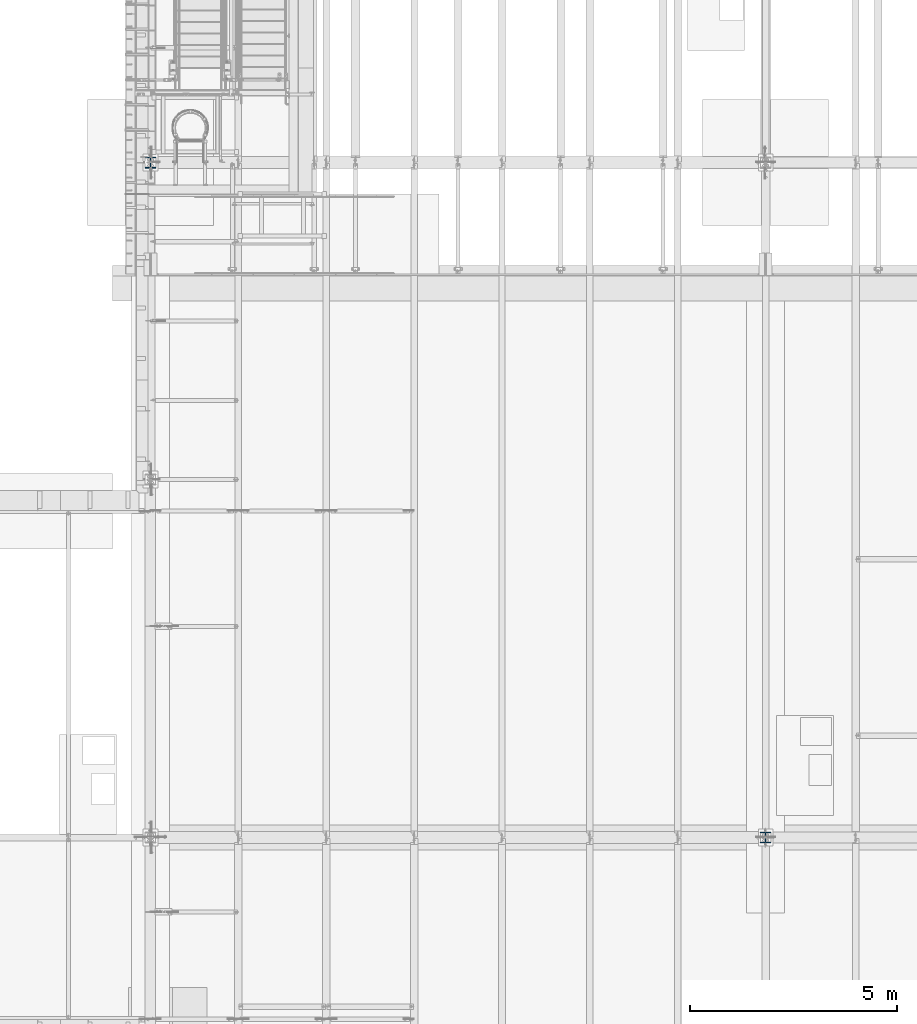
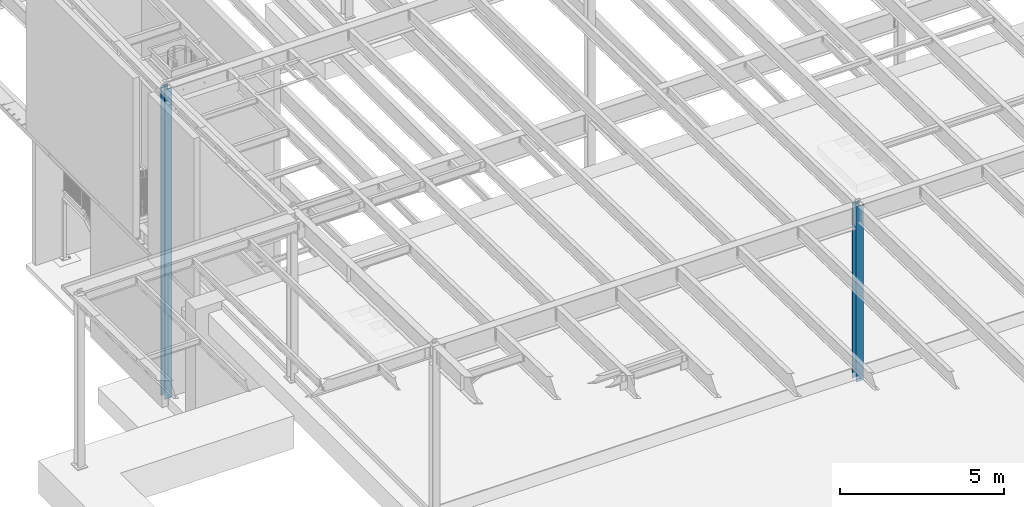
# One storey, part 900 of 1763: 2 columns, 2 elements without a shape of their own.
"""IFC2X3 building model written with IfcOpenShell, lengths in millimetres."""

from ifc_helpers import new_model, si_unit, frame, origin_with_axes, place, context, subcontext, project, spatial, faceted_brep, material, type_object, element, aggregate, save


model = new_model("IFC2X3")

# Units and contexts
model_context = context("Model", 3, precision=1e-05, world=origin_with_axes())
body_context = subcontext(model_context, "Body", "Model", "MODEL_VIEW")
ifc_project = project(units=[si_unit("LENGTHUNIT", "METRE", prefix="MILLI"), si_unit("AREAUNIT", "SQUARE_METRE"), si_unit("VOLUMEUNIT", "CUBIC_METRE"), si_unit("MASSUNIT", "GRAM", prefix="KILO"), si_unit("TIMEUNIT", "SECOND"), si_unit("PLANEANGLEUNIT", "RADIAN"), si_unit("SOLIDANGLEUNIT", "STERADIAN"), si_unit("THERMODYNAMICTEMPERATUREUNIT", "DEGREE_CELSIUS"), si_unit("LUMINOUSINTENSITYUNIT", "LUMEN")], contexts=[model_context])

# Site, building, storey
site_placement = place(None, origin_with_axes())
site = spatial("IfcSite", under=ifc_project, at=site_placement, CompositionType="ELEMENT")
building_placement = place(site_placement, origin_with_axes())
building = spatial("IfcBuilding", under=site, at=building_placement, Name="Undefined", CompositionType="ELEMENT")
storey_placement = place(building_placement, origin_with_axes())
storey = spatial("IfcBuildingStorey", under=building, at=storey_placement, Name="Undefined", CompositionType="ELEMENT", Elevation=0.0)

# Assembly, column
assembly_1_placement = place(storey_placement, origin_with_axes())
assembly_1 = element("IfcElementAssembly", 1, at=assembly_1_placement, inside=storey, Name="COLUMN", AssemblyPlace="NOTDEFINED", PredefinedType="RIGID_FRAME")
ifc_material = material(Name="STEEL/A992")
column_type_1 = type_object("IfcColumnType", Name="W10X49", PredefinedType="NOTDEFINED")
column_1_placement = place(assembly_1_placement, frame((-72491.0372736984, 13690.6, 5029.2), z_axis=(0.0, 1.0, 0.0), x_axis=(0.0, 0.0, 1.0)))
column_1 = element("IfcColumn", 2, at=column_1_placement, type_object=column_type_1, material=ifc_material, Name="COLUMN", ObjectType="W10X49", context=body_context, shape_type="Brep", body=[
    faceted_brep([(69.8500000000085, 127.0, -127.0), (69.8500000000085, 127.0, -112.712500000001), (6589.7125, 127.0, -112.7125), (6589.7125, 127.0, -127.0), (69.8500000000085, 3.96875, -112.712500000001), (6589.7125, 3.96875, -112.7125), (69.8500000000085, 3.96875, 112.712500000001), (6589.7125, 3.96875, 112.7125), (69.8500000000085, 127.0, 112.712500000001), (6589.7125, 127.0, 112.7125), (69.8500000000085, 127.0, 127.0), (6589.7125, 127.0, 127.0), (69.8500000000085, -127.0, 127.0), (6589.7125, -127.0, 127.0), (69.8500000000085, -127.0, 112.712500000001), (6589.7125, -127.0, 112.7125), (69.8500000000085, -3.96875, 112.712500000001), (6589.7125, -3.96875, 112.7125), (69.8500000000085, -3.96875, -112.712500000001), (6589.7125, -3.96875, -112.7125), (69.8500000000085, -127.0, -112.712500000001), (6589.7125, -127.0, -112.7125), (69.8500000000085, -127.0, -127.0), (6589.7125, -127.0, -127.0)], [[[0, 1, 2, 3]], [[1, 4, 5, 2]], [[4, 6, 7, 5]], [[6, 8, 9, 7]], [[8, 10, 11, 9]], [[10, 12, 13, 11]], [[12, 14, 15, 13]], [[14, 16, 17, 15]], [[16, 18, 19, 17]], [[18, 20, 21, 19]], [[20, 22, 23, 21]], [[22, 0, 3, 23]], [[5, 7, 9, 11, 13, 15, 17, 19, 21, 23, 3, 2]], [[22, 20, 18, 16, 14, 12, 10, 8, 6, 4, 1, 0]]]),
])
aggregate(assembly_1, [column_1])

assembly_2_placement = place(storey_placement, origin_with_axes())
assembly_2 = element("IfcElementAssembly", 3, at=assembly_2_placement, inside=storey, Name="COLUMN", AssemblyPlace="NOTDEFINED", PredefinedType="RIGID_FRAME")
column_type_2 = type_object("IfcColumnType", Name="W10X68", PredefinedType="NOTDEFINED")
column_2_placement = place(assembly_2_placement, frame((-87375.4372736983, 30022.8, -304.8), z_axis=(0.0, 1.0, 0.0), x_axis=(0.0, 0.0, 1.0)))
column_2 = element("IfcColumn", 4, at=column_2_placement, type_object=column_type_2, material=ifc_material, Name="COLUMN", ObjectType="W10X68", context=body_context, shape_type="Brep", body=[
    faceted_brep([(69.8499999999952, 128.587499999994, -131.762500000001), (69.8499999999952, 128.587499999994, -112.712500000001), (11582.3999999952, 128.587499999994, -112.712500000001), (11582.3999999952, 128.587499999994, -131.762500000001), (69.8499999999952, 6.35000000000582, -112.712500000001), (11582.3999999952, 6.35000000000582, -112.712500000001), (69.8499999999952, 6.35000000000582, 112.712500000001), (11582.3999999952, 6.35000000000582, 112.712500000001), (69.8499999999952, 128.587499999994, 112.712500000001), (11582.3999999952, 128.587499999994, 112.712500000001), (69.8499999999952, 128.587499999994, 131.762500000001), (11582.3999999952, 128.587499999994, 131.762500000001), (69.8499999999952, -128.587499999994, 131.762500000001), (11582.3999999952, -128.587499999994, 131.762500000001), (69.8499999999952, -128.587499999994, 112.712500000001), (11582.3999999952, -128.587499999994, 112.712500000001), (69.8499999999952, -6.35000000000582, 112.712500000001), (11582.3999999952, -6.35000000000582, 112.712500000001), (69.8499999999952, -6.35000000000582, -112.712500000001), (11582.3999999952, -6.35000000000582, -112.712500000001), (69.8499999999952, -128.587499999994, -112.712500000001), (11582.3999999952, -128.587499999994, -112.712500000001), (69.8499999999952, -128.587499999994, -131.762500000001), (11582.3999999952, -128.587499999994, -131.762500000001)], [[[0, 1, 2, 3]], [[1, 4, 5, 2]], [[4, 6, 7, 5]], [[6, 8, 9, 7]], [[8, 10, 11, 9]], [[10, 12, 13, 11]], [[12, 14, 15, 13]], [[14, 16, 17, 15]], [[16, 18, 19, 17]], [[18, 20, 21, 19]], [[20, 22, 23, 21]], [[22, 0, 3, 23]], [[5, 7, 9, 11, 13, 15, 17, 19, 21, 23, 3, 2]], [[22, 20, 18, 16, 14, 12, 10, 8, 6, 4, 1, 0]]]),
])
aggregate(assembly_2, [column_2])

save(model, "model.ifc")
